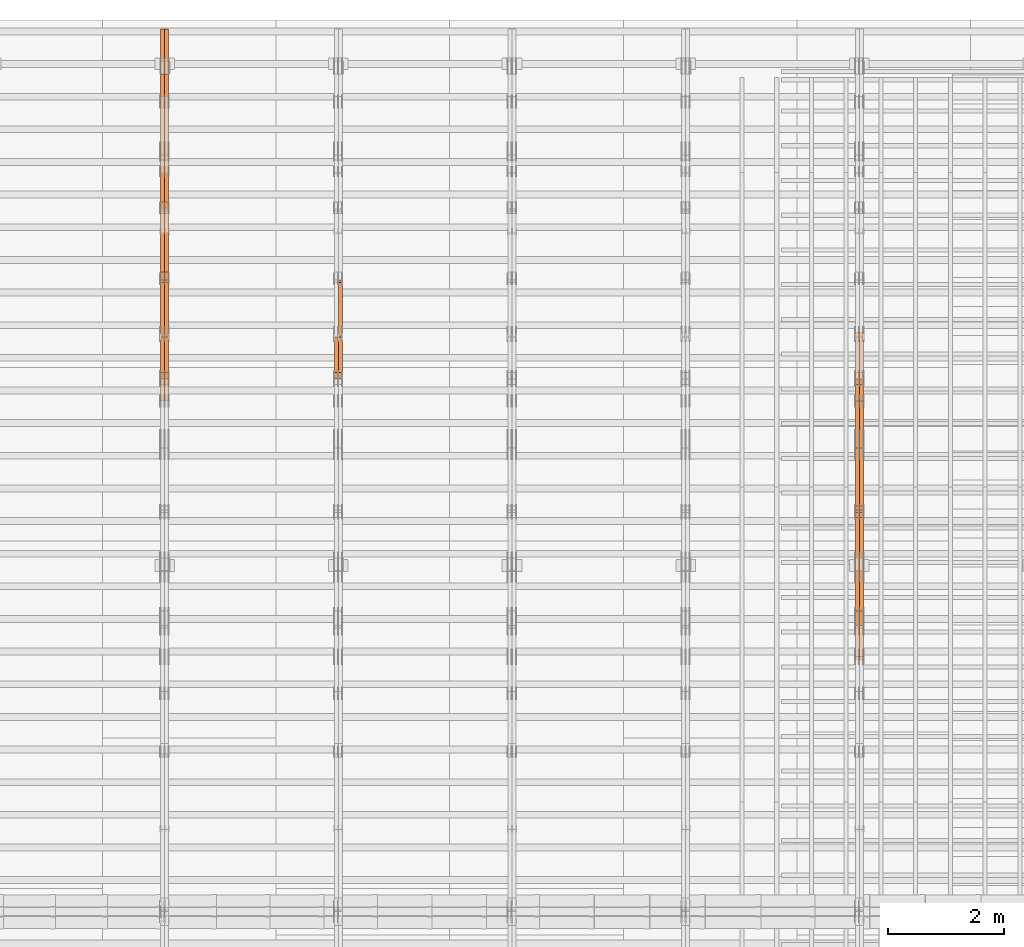
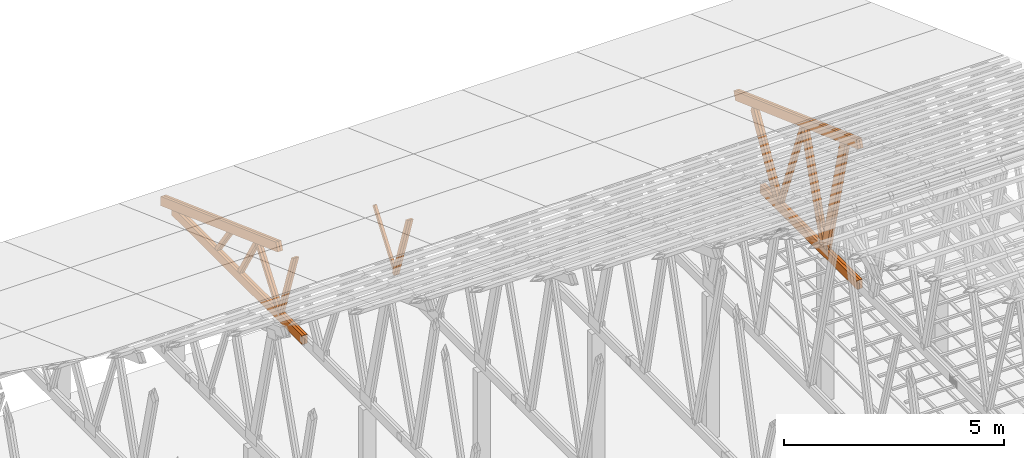
# One storey, part 61 of 189: 27 proxies.
"""IFC2X3 building model written with IfcOpenShell, lengths in millimetres."""

import ifcopenshell
import ifcopenshell.guid

model = None  # the IFC model being written
_history = None  # IfcOwnerHistory: only IFC2X3 demands one
_inside = {}  # id of a spatial element -> (the spatial element, [elements in it])
_under = {}  # id of a project, library or spatial element -> (it, [spatial elements below it])
_declared = {}  # id of a project -> (the project, [libraries it declares])
_typed = {}  # id of a type object -> (the type object, [elements of that type])
_made_of = {}  # id of a material, layer set ... -> (it, [elements and type objects made of it])


def new_model(schema):
    """Start an empty IFC model of exactly this schema.

    Asked for "IFC4X3", IfcOpenShell would pick the latest addendum, in which some entities
    have other attributes; the version numbers below select the first issue.
    IFC2X3 requires an IfcOwnerHistory on every rooted entity: one is made here for all.
    """
    global model, _history
    if schema == "IFC4X3":
        model = ifcopenshell.file(schema_version=(4, 3, 0, 0))
    else:
        model = ifcopenshell.file(schema=schema)
    _inside.clear()
    _under.clear()
    _declared.clear()
    _typed.clear()
    _made_of.clear()
    _history = None
    if model.schema == "IFC2X3":
        org = make("IfcOrganization", Name="unknown")
        user = make(
            "IfcPersonAndOrganization",
            ThePerson=make("IfcPerson", FamilyName="unknown"),
            TheOrganization=org,
        )
        app = make(
            "IfcApplication",
            ApplicationDeveloper=org,
            Version="unknown",
            ApplicationFullName="unknown",
            ApplicationIdentifier="unknown",
        )
        _history = make(
            "IfcOwnerHistory",
            OwningUser=user,
            OwningApplication=app,
            ChangeAction="ADDED",
            CreationDate=0,
        )
    return model


def make(cls, **values):
    """One entity of the class cls with the attributes given. An attribute that is None is left unset."""
    return model.create_entity(
        cls, **{name: value for name, value in values.items() if value is not None}
    )


def entity(cls, *values):
    """Any entity or typed value of the class cls, its attributes in the order of the schema. None: left unset."""
    e = model.create_entity(cls)
    for i, value in enumerate(values):
        if value is not None:
            e[i] = value
    return e


def rooted(cls, **values):
    """An entity with a GlobalId (a new one), such as an element, a storey or a relation."""
    return make(cls, GlobalId=ifcopenshell.guid.new(), OwnerHistory=_history, **values)


def si_unit(unit_type, name, prefix=None):
    """IfcSIUnit, for example si_unit("LENGTHUNIT", "METRE", prefix="MILLI")."""
    return make("IfcSIUnit", UnitType=unit_type, Prefix=prefix, Name=name)


def converted_unit(unit_type, name, factor, base, dimensions=None, offset=None):
    """IfcConversionBasedUnit, such as the inch: factor (a typed value) times the base unit."""
    return make(
        "IfcConversionBasedUnit"
        if offset is None
        else "IfcConversionBasedUnitWithOffset",
        ConversionOffset=offset,
        Dimensions=None
        if dimensions is None
        else entity("IfcDimensionalExponents", *dimensions),
        UnitType=unit_type,
        Name=name,
        ConversionFactor=make(
            "IfcMeasureWithUnit", ValueComponent=factor, UnitComponent=base
        ),
    )


def derived_unit(unit_type, elements):
    """IfcDerivedUnit: a product of units, each with its exponent."""
    return make(
        "IfcDerivedUnit",
        Elements=[
            make("IfcDerivedUnitElement", Unit=unit, Exponent=power)
            for unit, power in elements
        ],
        UnitType=unit_type,
    )


def assignment(units):
    """IfcUnitAssignment: the units of a project."""
    return None if units is None else make("IfcUnitAssignment", Units=units)


def point(xyz):
    """IfcCartesianPoint."""
    return None if xyz is None else make("IfcCartesianPoint", Coordinates=xyz)


def direction(xyz):
    """IfcDirection."""
    return None if xyz is None else make("IfcDirection", DirectionRatios=xyz)


def frame(location, z_axis=None, x_axis=None):
    """IfcAxis2Placement3D, a coordinate frame: its origin and axes. An axis left out is left unset."""
    return make(
        "IfcAxis2Placement3D",
        Location=point(location),
        Axis=direction(z_axis),
        RefDirection=direction(x_axis),
    )


def frame_2d(location, x_axis=None):
    """IfcAxis2Placement2D, a coordinate frame in the plane: its origin and x axis."""
    return make(
        "IfcAxis2Placement2D", Location=point(location), RefDirection=direction(x_axis)
    )


def origin():
    """The frame at (0, 0, 0) with its axes left unset."""
    return frame((0.0, 0.0, 0.0))


def origin_2d_with_axis():
    """The frame at (0, 0) in the plane with the x axis (1, 0) written out."""
    return frame_2d((0.0, 0.0), x_axis=(1.0, 0.0))


def place(relative_to, where):
    """IfcLocalPlacement: puts the frame where relative to a parent placement (None: the world)."""
    return make(
        "IfcLocalPlacement", PlacementRelTo=relative_to, RelativePlacement=where
    )


def context(
    kind, dimensions, precision=None, world=None, true_north=None, identifier=None
):
    """IfcGeometricRepresentationContext, for example the 3D "Model" context."""
    return make(
        "IfcGeometricRepresentationContext",
        ContextIdentifier=identifier,
        ContextType=kind,
        CoordinateSpaceDimension=dimensions,
        Precision=precision,
        WorldCoordinateSystem=world,
        TrueNorth=true_north,
    )


def subcontext(parent, identifier, kind, view, scale=None):
    """IfcGeometricRepresentationSubContext, for example "Body" below "Model"."""
    return make(
        "IfcGeometricRepresentationSubContext",
        ContextIdentifier=identifier,
        ContextType=kind,
        ParentContext=parent,
        TargetScale=scale,
        TargetView=view,
    )


def project(units=None, contexts=None):
    """IfcProject with its units and contexts."""
    return rooted(
        "IfcProject",
        Name="project",
        RepresentationContexts=contexts,
        UnitsInContext=assignment(units),
    )


def spatial(cls, under=None, at=None, **own):
    """A site, building, storey or space (cls), placed at a placement, below another one or the project."""
    s = rooted(cls, ObjectPlacement=at, **own)
    if under is not None:
        _under.setdefault(under.id(), (under, []))[1].append(s)
    return s


def polyline(points):
    """IfcPolyline through the points."""
    return make("IfcPolyline", Points=[point(p) for p in points])


def profile(cls, at=None, kind="AREA", **sizes):
    """A parametric profile (cls). Its sizes go by their IFC names, for example OverallWidth=200.0."""
    return make(cls, ProfileType=kind, Position=at, **sizes)


def rectangle(**sizes):
    """IfcRectangleProfileDef."""
    return profile("IfcRectangleProfileDef", **sizes)


def outline(outer, holes=None, kind="AREA"):
    """IfcArbitraryClosedProfileDef: a profile drawn as a closed curve; with holes, ...WithVoids."""
    if holes is None:
        return make("IfcArbitraryClosedProfileDef", ProfileType=kind, OuterCurve=outer)
    return make(
        "IfcArbitraryProfileDefWithVoids",
        ProfileType=kind,
        OuterCurve=outer,
        InnerCurves=holes,
    )


def extrude(swept, where, along, depth):
    """IfcExtrudedAreaSolid: the profile swept, set in the frame where, extruded along a direction by depth."""
    return make(
        "IfcExtrudedAreaSolid",
        SweptArea=swept,
        Position=where,
        ExtrudedDirection=direction(along),
        Depth=depth,
    )


def shape(context_of_items, identifier, shape_type, items):
    """IfcShapeRepresentation: the items that make up one representation, for example the "Body"."""
    return make(
        "IfcShapeRepresentation",
        ContextOfItems=context_of_items,
        RepresentationIdentifier=identifier,
        RepresentationType=shape_type,
        Items=items,
    )


def source(mapping_origin, context_of_items, identifier, shape_type, items):
    """IfcRepresentationMap: a shape defined once, which mapped items show again and again."""
    return make(
        "IfcRepresentationMap",
        MappingOrigin=mapping_origin,
        MappedRepresentation=shape(context_of_items, identifier, shape_type, items),
    )


def transform(
    local_origin,
    x_axis=None,
    y_axis=None,
    z_axis=None,
    scale=None,
    scale2=None,
    scale3=None,
    uniform=True,
):
    """IfcCartesianTransformationOperator3D, or its non-uniform kind. x_axis, y_axis, z_axis: its Axis1, 2, 3."""
    if uniform:
        return make(
            "IfcCartesianTransformationOperator3D",
            Axis1=direction(x_axis),
            Axis2=direction(y_axis),
            LocalOrigin=point(local_origin),
            Scale=scale,
            Axis3=direction(z_axis),
        )
    return make(
        "IfcCartesianTransformationOperator3DnonUniform",
        Axis1=direction(x_axis),
        Axis2=direction(y_axis),
        LocalOrigin=point(local_origin),
        Scale=scale,
        Axis3=direction(z_axis),
        Scale2=scale2,
        Scale3=scale3,
    )


def mapped(mapping_source, mapping_target):
    """IfcMappedItem: shows the shape of a source again, moved by a transform."""
    return make(
        "IfcMappedItem", MappingSource=mapping_source, MappingTarget=mapping_target
    )


def material(Name=None, Category=None):
    """IfcMaterial."""
    return make("IfcMaterial", Name=Name, Category=Category)


def made_of(thing, what):
    """Note that an element or type object is made of a material, layer set ...; save() writes the relation."""
    if what is not None:
        _made_of.setdefault(what.id(), (what, []))[1].append(thing)
    return thing


def type_object(cls, material=None, **own):
    """A type object (cls), such as IfcWallType, which elements share."""
    return made_of(rooted(cls, **own), material)


def type_shapes(of_type, sources):
    """Give a type object the sources (RepresentationMaps) that its elements show as mapped items."""
    of_type.RepresentationMaps = sources


def element(
    cls,
    number,
    at=None,
    inside=None,
    cuts=None,
    type_object=None,
    material=None,
    context=None,
    identifier="Body",
    shape_type=None,
    held_by="IfcProductDefinitionShape",
    body=None,
    shapes=None,
    **own,
):
    """One element of the class cls, such as IfcWall. Its Tag is "e" and its number.

    at: its placement. inside: the storey or other place that contains it. cuts: it is an
    opening in that element (IfcRelVoidsElement). A single representation is given by context,
    identifier, shape_type and body (its items); several are given by shapes. held_by: the class
    of the entity that holds the representations. save() writes the other relations.
    """
    e = rooted(cls, Tag="e%d" % number, ObjectPlacement=at, **own)
    if body is not None:
        shapes = [shape(context, identifier, shape_type, body)]
    if shapes is not None:
        e.Representation = make(held_by, Representations=shapes)
    if inside is not None:
        _inside.setdefault(inside.id(), (inside, []))[1].append(e)
    if cuts is not None:
        rooted(
            "IfcRelVoidsElement", RelatingBuildingElement=cuts, RelatedOpeningElement=e
        )
    if type_object is not None:
        _typed.setdefault(type_object.id(), (type_object, []))[1].append(e)
    return made_of(e, material)


def aggregate(whole, parts):
    """IfcRelAggregates: a whole, such as a stair, and the parts it consists of."""
    return rooted("IfcRelAggregates", RelatingObject=whole, RelatedObjects=parts)


def save(model, path):
    """Write the relations noted so far, then the file.

    IfcRelAggregates (storeys below a building ...), IfcRelContainedInSpatialStructure (elements
    in a storey), IfcRelDefinesByType, IfcRelAssociatesMaterial and IfcRelDeclares: one each for
    every whole, place, type object, material and project.
    """
    for whole, parts in _under.values():
        aggregate(whole, parts)
    for where, things in _inside.values():
        rooted(
            "IfcRelContainedInSpatialStructure",
            RelatedElements=things,
            RelatingStructure=where,
        )
    for kind, things in _typed.values():
        rooted("IfcRelDefinesByType", RelatedObjects=things, RelatingType=kind)
    for what, things in _made_of.values():
        rooted("IfcRelAssociatesMaterial", RelatedObjects=things, RelatingMaterial=what)
    for by, libraries in _declared.values():
        rooted("IfcRelDeclares", RelatingContext=by, RelatedDefinitions=libraries)
    model.write(path)


model = new_model("IFC2X3")

# Units and contexts
model_context = context("Model", 3, precision=0.01, world=origin(), true_north=direction((6.12303176911189e-17, 1.0)))
body_context = subcontext(model_context, "Body", "Model", "MODEL_VIEW")
ifc_project = project(units=[si_unit("LENGTHUNIT", "METRE", prefix="MILLI"), si_unit("AREAUNIT", "SQUARE_METRE"), si_unit("VOLUMEUNIT", "CUBIC_METRE"), converted_unit("PLANEANGLEUNIT", "DEGREE", entity("IfcRatioMeasure", 0.0174532925199433), si_unit("PLANEANGLEUNIT", "RADIAN"), dimensions=[0, 0, 0, 0, 0, 0, 0]), si_unit("MASSUNIT", "GRAM", prefix="KILO"), derived_unit("MASSDENSITYUNIT", [(si_unit("MASSUNIT", "GRAM", prefix="KILO"), 1), (si_unit("LENGTHUNIT", "METRE"), -3)]), si_unit("TIMEUNIT", "SECOND"), si_unit("FREQUENCYUNIT", "HERTZ"), si_unit("THERMODYNAMICTEMPERATUREUNIT", "DEGREE_CELSIUS"), derived_unit("THERMALTRANSMITTANCEUNIT", [(si_unit("MASSUNIT", "GRAM", prefix="KILO"), 1), (si_unit("THERMODYNAMICTEMPERATUREUNIT", "KELVIN"), -1), (si_unit("TIMEUNIT", "SECOND"), -3)]), derived_unit("VOLUMETRICFLOWRATEUNIT", [(si_unit("LENGTHUNIT", "METRE"), 3), (si_unit("TIMEUNIT", "SECOND"), -1)]), si_unit("ELECTRICCURRENTUNIT", "AMPERE"), si_unit("ELECTRICVOLTAGEUNIT", "VOLT"), si_unit("POWERUNIT", "WATT"), si_unit("FORCEUNIT", "NEWTON"), si_unit("ILLUMINANCEUNIT", "LUX"), si_unit("LUMINOUSFLUXUNIT", "LUMEN"), si_unit("LUMINOUSINTENSITYUNIT", "CANDELA"), derived_unit("USERDEFINED", [(si_unit("MASSUNIT", "GRAM", prefix="KILO"), -1), (si_unit("LENGTHUNIT", "METRE"), -2), (si_unit("TIMEUNIT", "SECOND"), 3), (si_unit("LUMINOUSFLUXUNIT", "LUMEN"), 1)]), derived_unit("LINEARVELOCITYUNIT", [(si_unit("LENGTHUNIT", "METRE"), 1), (si_unit("TIMEUNIT", "SECOND"), -1)]), si_unit("PRESSUREUNIT", "PASCAL"), derived_unit("USERDEFINED", [(si_unit("LENGTHUNIT", "METRE"), -2), (si_unit("MASSUNIT", "GRAM", prefix="KILO"), 1), (si_unit("TIMEUNIT", "SECOND"), -2)])], contexts=[model_context])

# Site, building, storey
site_placement = place(None, origin())
site = spatial("IfcSite", under=ifc_project, at=site_placement, CompositionType="ELEMENT")
building_placement = place(site_placement, origin())
building = spatial("IfcBuilding", under=site, at=building_placement, CompositionType="ELEMENT")
storey_placement = place(building_placement, origin())
storey = spatial("IfcBuildingStorey", under=building, at=storey_placement, Name="Default", CompositionType="ELEMENT", Elevation=0.0)

# Proxies
ifc_material_1 = material(Name="IfcSurfaceStyle #241136")
building_element_proxy_type_1 = type_object("IfcBuildingElementProxyType", Name="T1-W1 241134", PredefinedType="NOTDEFINED", material=ifc_material_1)
shared_shape_1 = source(origin(), body_context, "Body", "SweptSolid", [
    extrude(outline(polyline([(-1996.99427801396, -109.999889649051), (1271.09905152223, -109.999889649051), (1448.88120817726, -0.000113190727324008), (1421.70802776002, 109.999946244415), (-2144.69400944554, 109.999946244415), (-1996.99427801396, -109.999889649051)])), frame((1448.88120817726, 110.000265670598, 0.0), z_axis=(0.0, 0.0, 1.0), x_axis=(-1.0, 0.0, 0.0)), (0.0, 0.0, 1.0), 69.9999999999998),
])
type_shapes(building_element_proxy_type_1, [shared_shape_1])
proxy_1_placement = place(building_placement, frame((45300.0, 20558.6774904859, 218.61972674968), z_axis=(-1.0, 0.0, 0.0), x_axis=(0.0, -0.239819839925979, 0.970817410421691)))
element("IfcBuildingElementProxy", 1, at=proxy_1_placement, inside=storey, type_object=building_element_proxy_type_1, material=ifc_material_1, Name="T1-W1", context=body_context, shape_type="MappedRepresentation", body=[
    mapped(shared_shape_1, transform((0.0, 0.0, 0.0), scale=1.0)),
])
ifc_material_2 = material(Name="IfcSurfaceStyle #241070")
building_element_proxy_type_2 = type_object("IfcBuildingElementProxyType", Name="T1-W1 241068", PredefinedType="NOTDEFINED", material=ifc_material_2)
shared_shape_2 = source(origin(), body_context, "Body", "SweptSolid", [
    extrude(outline(polyline([(-1996.99427801396, -109.999889649051), (1271.09905152223, -109.999889649051), (1448.88120817726, -0.000113190727324008), (1421.70802776002, 109.999946244415), (-2144.69400944554, 109.999946244415), (-1996.99427801396, -109.999889649051)])), frame((1448.88120817726, 110.000265670598, 0.0), z_axis=(0.0, 0.0, 1.0), x_axis=(-1.0, 0.0, 0.0)), (0.0, 0.0, 1.0), 69.9999999999998),
])
type_shapes(building_element_proxy_type_2, [shared_shape_2])
proxy_2_placement = place(building_placement, frame((45230.0, 20558.6774904859, 218.61972674968), z_axis=(-1.0, 0.0, 0.0), x_axis=(0.0, -0.239819839925979, 0.970817410421691)))
element("IfcBuildingElementProxy", 2, at=proxy_2_placement, inside=storey, type_object=building_element_proxy_type_2, material=ifc_material_2, Name="T1-W1", context=body_context, shape_type="MappedRepresentation", body=[
    mapped(shared_shape_2, transform((0.0, 0.0, 0.0), scale=1.0)),
])
ifc_material_3 = material(Name="IfcSurfaceStyle #240872")
building_element_proxy_type_3 = type_object("IfcBuildingElementProxyType", Name="T1-W4 240870", PredefinedType="NOTDEFINED", material=ifc_material_3)
shared_shape_3 = source(origin(), body_context, "Body", "SweptSolid", [
    extrude(outline(polyline([(-1742.90513395849, -84.9997422414737), (1181.3544167489, -84.9997422414737), (1178.19398821251, -0.000208932978430543), (1071.44989130457, 84.999846707963), (-1688.09316230749, 84.999846707963), (-1742.90513395849, -84.9997422414737)])), frame((1181.35452116422, 84.999886337523, 0.0), z_axis=(0.0, 0.0, 1.0), x_axis=(-1.0, 0.0, 0.0)), (0.0, 0.0, 1.0), 69.9999999999998),
])
type_shapes(building_element_proxy_type_3, [shared_shape_3])
proxy_3_placement = place(building_placement, frame((45300.0, 21724.6281517871, 2976.00232464744), z_axis=(-1.0, 0.0, 0.0), x_axis=(0.0, -0.306868406216495, -0.951751953644514)))
element("IfcBuildingElementProxy", 3, at=proxy_3_placement, inside=storey, type_object=building_element_proxy_type_3, material=ifc_material_3, Name="T1-W4", context=body_context, shape_type="MappedRepresentation", body=[
    mapped(shared_shape_3, transform((0.0, 0.0, 0.0), scale=1.0)),
])
ifc_material_4 = material(Name="IfcSurfaceStyle #240806")
building_element_proxy_type_4 = type_object("IfcBuildingElementProxyType", Name="T1-W4 240804", PredefinedType="NOTDEFINED", material=ifc_material_4)
shared_shape_4 = source(origin(), body_context, "Body", "SweptSolid", [
    extrude(outline(polyline([(-1742.90513395849, -84.9997422414737), (1181.3544167489, -84.9997422414737), (1178.19398821251, -0.000208932978430543), (1071.44989130457, 84.999846707963), (-1688.09316230749, 84.999846707963), (-1742.90513395849, -84.9997422414737)])), frame((1181.35452116422, 84.999886337523, 0.0), z_axis=(0.0, 0.0, 1.0), x_axis=(-1.0, 0.0, 0.0)), (0.0, 0.0, 1.0), 69.9999999999998),
])
type_shapes(building_element_proxy_type_4, [shared_shape_4])
proxy_4_placement = place(building_placement, frame((45230.0, 21724.6281517871, 2976.00232464744), z_axis=(-1.0, 0.0, 0.0), x_axis=(0.0, -0.306868406216495, -0.951751953644514)))
element("IfcBuildingElementProxy", 4, at=proxy_4_placement, inside=storey, type_object=building_element_proxy_type_4, material=ifc_material_4, Name="T1-W4", context=body_context, shape_type="MappedRepresentation", body=[
    mapped(shared_shape_4, transform((0.0, 0.0, 0.0), scale=1.0)),
])
ifc_material_5 = material(Name="IfcSurfaceStyle #240608")
building_element_proxy_type_5 = type_object("IfcBuildingElementProxyType", Name="T1-W8 240606", PredefinedType="NOTDEFINED", material=ifc_material_5)
shared_shape_5 = source(origin(), body_context, "Body", "SweptSolid", [
    extrude(outline(polyline([(-1700.10906247918, -47.4998559987011), (1140.60243146647, -47.4998559987011), (1179.56122089033, 0.000120838919977206), (1161.65086478184, 47.4997955792411), (-1781.70545465947, 47.4997955792411), (-1700.10906247918, -47.4998559987011)])), frame((1179.56128464708, 47.5000634692093, 0.0), z_axis=(0.0, 0.0, 1.0), x_axis=(-1.0, 0.0, 0.0)), (0.0, 0.0, 1.0), 69.9999999999998),
])
type_shapes(building_element_proxy_type_5, [shared_shape_5])
proxy_5_placement = place(building_placement, frame((45300.0, 22687.5385403115, 228.241249073207), z_axis=(-1.0, 0.0, 0.0), x_axis=(0.0, -0.352814979177604, 0.93569310698963)))
element("IfcBuildingElementProxy", 5, at=proxy_5_placement, inside=storey, type_object=building_element_proxy_type_5, material=ifc_material_5, Name="T1-W8", context=body_context, shape_type="MappedRepresentation", body=[
    mapped(shared_shape_5, transform((0.0, 0.0, 0.0), scale=1.0)),
])
ifc_material_6 = material(Name="IfcSurfaceStyle #240542")
building_element_proxy_type_6 = type_object("IfcBuildingElementProxyType", Name="T1-W8 240540", PredefinedType="NOTDEFINED", material=ifc_material_6)
shared_shape_6 = source(origin(), body_context, "Body", "SweptSolid", [
    extrude(outline(polyline([(-1700.10906247918, -47.4998559987011), (1140.60243146647, -47.4998559987011), (1179.56122089033, 0.000120838919977206), (1161.65086478184, 47.4997955792411), (-1781.70545465947, 47.4997955792411), (-1700.10906247918, -47.4998559987011)])), frame((1179.56128464708, 47.5000634692093, 0.0), z_axis=(0.0, 0.0, 1.0), x_axis=(-1.0, 0.0, 0.0)), (0.0, 0.0, 1.0), 69.9999999999998),
])
type_shapes(building_element_proxy_type_6, [shared_shape_6])
proxy_6_placement = place(building_placement, frame((45230.0, 22687.5385403115, 228.241249073207), z_axis=(-1.0, 0.0, 0.0), x_axis=(0.0, -0.352814979177604, 0.93569310698963)))
element("IfcBuildingElementProxy", 6, at=proxy_6_placement, inside=storey, type_object=building_element_proxy_type_6, material=ifc_material_6, Name="T1-W8", context=body_context, shape_type="MappedRepresentation", body=[
    mapped(shared_shape_6, transform((0.0, 0.0, 0.0), scale=1.0)),
])
ifc_material_7 = material(Name="IfcSurfaceStyle #240344")
building_element_proxy_type_7 = type_object("IfcBuildingElementProxyType", Name="T1-W2 240342", PredefinedType="NOTDEFINED", material=ifc_material_7)
shared_shape_7 = source(origin(), body_context, "Body", "SweptSolid", [
    extrude(outline(polyline([(-1361.89144606429, -97.5000598486876), (887.613245225805, -97.5000598486876), (904.774262962339, 0.000302345139042259), (818.892339969004, 97.4999086761182), (-1249.38840209286, 97.4999086761182), (-1361.89144606429, -97.5000598486876)])), frame((904.774262962339, 97.5000966763391, 0.0), z_axis=(0.0, 0.0, 1.0), x_axis=(-1.0, 0.0, 0.0)), (0.0, 0.0, 1.0), 69.9999999999999),
])
type_shapes(building_element_proxy_type_7, [shared_shape_7])
proxy_7_placement = place(building_placement, frame((45300.0, 24033.6159173732, 2110.89189244614), z_axis=(-1.0, 0.0, 0.0), x_axis=(0.0, -0.5, -0.866025403784439)))
element("IfcBuildingElementProxy", 7, at=proxy_7_placement, inside=storey, type_object=building_element_proxy_type_7, material=ifc_material_7, Name="T1-W2", context=body_context, shape_type="MappedRepresentation", body=[
    mapped(shared_shape_7, transform((0.0, 0.0, 0.0), scale=1.0)),
])
ifc_material_8 = material(Name="IfcSurfaceStyle #240278")
building_element_proxy_type_8 = type_object("IfcBuildingElementProxyType", Name="T1-W2 240276", PredefinedType="NOTDEFINED", material=ifc_material_8)
shared_shape_8 = source(origin(), body_context, "Body", "SweptSolid", [
    extrude(outline(polyline([(-1361.89144606429, -97.5000598486876), (887.613245225805, -97.5000598486876), (904.774262962339, 0.000302345139042259), (818.892339969004, 97.4999086761182), (-1249.38840209286, 97.4999086761182), (-1361.89144606429, -97.5000598486876)])), frame((904.774262962339, 97.5000966763391, 0.0), z_axis=(0.0, 0.0, 1.0), x_axis=(-1.0, 0.0, 0.0)), (0.0, 0.0, 1.0), 69.9999999999999),
])
type_shapes(building_element_proxy_type_8, [shared_shape_8])
proxy_8_placement = place(building_placement, frame((45230.0, 24033.6159173732, 2110.89189244614), z_axis=(-1.0, 0.0, 0.0), x_axis=(0.0, -0.5, -0.866025403784439)))
element("IfcBuildingElementProxy", 8, at=proxy_8_placement, inside=storey, type_object=building_element_proxy_type_8, material=ifc_material_8, Name="T1-W2", context=body_context, shape_type="MappedRepresentation", body=[
    mapped(shared_shape_8, transform((0.0, 0.0, 0.0), scale=1.0)),
])
ifc_material_9 = material(Name="IfcSurfaceStyle #238268")
building_element_proxy_type_9 = type_object("IfcBuildingElementProxyType", Name="T1-B4 238266", PredefinedType="NOTDEFINED", material=ifc_material_9)
shared_shape_9 = source(origin(), body_context, "Body", "SweptSolid", [
    extrude(rectangle(XDim=4408.2412109375, YDim=245.000000000001, at=origin_2d_with_axis()), frame((2204.12060546875, 122.5, 0.0), z_axis=(0.0, 0.0, 1.0), x_axis=(-1.0, 0.0, 0.0)), (0.0, 0.0, 1.0), 69.9999999999997),
])
type_shapes(building_element_proxy_type_9, [shared_shape_9])
proxy_9_placement = place(building_placement, frame((45300.0, 19161.7587890625, 245.0), z_axis=(-1.0, 0.0, 0.0), x_axis=(0.0, 1.0, 0.0)))
element("IfcBuildingElementProxy", 9, at=proxy_9_placement, inside=storey, type_object=building_element_proxy_type_9, material=ifc_material_9, Name="T1-B4", context=body_context, shape_type="MappedRepresentation", body=[
    mapped(shared_shape_9, transform((0.0, 0.0, 0.0), scale=1.0)),
])
ifc_material_10 = material(Name="IfcSurfaceStyle #238211")
building_element_proxy_type_10 = type_object("IfcBuildingElementProxyType", Name="T1-B4 238209", PredefinedType="NOTDEFINED", material=ifc_material_10)
shared_shape_10 = source(origin(), body_context, "Body", "SweptSolid", [
    extrude(rectangle(XDim=4408.2412109375, YDim=245.000000000001, at=origin_2d_with_axis()), frame((2204.12060546875, 122.5, 0.0), z_axis=(0.0, 0.0, 1.0), x_axis=(-1.0, 0.0, 0.0)), (0.0, 0.0, 1.0), 69.9999999999997),
])
type_shapes(building_element_proxy_type_10, [shared_shape_10])
proxy_10_placement = place(building_placement, frame((45230.0, 19161.7587890625, 245.0), z_axis=(-1.0, 0.0, 0.0), x_axis=(0.0, 1.0, 0.0)))
element("IfcBuildingElementProxy", 10, at=proxy_10_placement, inside=storey, type_object=building_element_proxy_type_10, material=ifc_material_10, Name="T1-B4", context=body_context, shape_type="MappedRepresentation", body=[
    mapped(shared_shape_10, transform((0.0, 0.0, 0.0), scale=1.0)),
])
ifc_material_11 = material(Name="IfcSurfaceStyle #237224")
building_element_proxy_type_11 = type_object("IfcBuildingElementProxyType", Name="T1-T1 237222", PredefinedType="NOTDEFINED", material=ifc_material_11)
shared_shape_11 = source(origin(), body_context, "Body", "SweptSolid", [
    extrude(outline(polyline([(-2964.99982426074, -122.499947708046), (2964.99981923522, -122.499947708046), (2964.99984513599, 122.499947708046), (-2964.99984011047, 122.499947708046), (-2964.99982426074, -122.499947708046)])), frame((2964.99984513599, 122.499998966405, 0.0), z_axis=(0.0, 0.0, 1.0), x_axis=(-1.0, 0.0, 0.0)), (0.0, 0.0, 1.0), 69.9999999999996),
])
type_shapes(building_element_proxy_type_11, [shared_shape_11])
proxy_11_placement = place(building_placement, frame((45300.0, 24681.3398262186, 1893.12531804384), z_axis=(-1.0, 0.0, 0.0), x_axis=(0.0, -0.939692620785908, 0.342020143325669)))
element("IfcBuildingElementProxy", 11, at=proxy_11_placement, inside=storey, type_object=building_element_proxy_type_11, material=ifc_material_11, Name="T1-T1", context=body_context, shape_type="MappedRepresentation", body=[
    mapped(shared_shape_11, transform((0.0, 0.0, 0.0), scale=1.0)),
])
ifc_material_12 = material(Name="IfcSurfaceStyle #237167")
building_element_proxy_type_12 = type_object("IfcBuildingElementProxyType", Name="T1-T1 237165", PredefinedType="NOTDEFINED", material=ifc_material_12)
shared_shape_12 = source(origin(), body_context, "Body", "SweptSolid", [
    extrude(outline(polyline([(-2964.99982426074, -122.499947708046), (2964.99981923522, -122.499947708046), (2964.99984513599, 122.499947708046), (-2964.99984011047, 122.499947708046), (-2964.99982426074, -122.499947708046)])), frame((2964.99984513599, 122.499998966405, 0.0), z_axis=(0.0, 0.0, 1.0), x_axis=(-1.0, 0.0, 0.0)), (0.0, 0.0, 1.0), 69.9999999999996),
])
type_shapes(building_element_proxy_type_12, [shared_shape_12])
proxy_12_placement = place(building_placement, frame((45230.0, 24681.3398262186, 1893.12531804384), z_axis=(-1.0, 0.0, 0.0), x_axis=(0.0, -0.939692620785908, 0.342020143325669)))
element("IfcBuildingElementProxy", 12, at=proxy_12_placement, inside=storey, type_object=building_element_proxy_type_12, material=ifc_material_12, Name="T1-T1", context=body_context, shape_type="MappedRepresentation", body=[
    mapped(shared_shape_12, transform((0.0, 0.0, 0.0), scale=1.0)),
])
ifc_material_13 = material(Name="IfcSurfaceStyle #192710")
building_element_proxy_type_13 = type_object("IfcBuildingElementProxyType", Name="T1-W9 192708", PredefinedType="NOTDEFINED", material=ifc_material_13)
shared_shape_13 = source(origin(), body_context, "Body", "SweptSolid", [
    extrude(outline(polyline([(-1151.44310138162, -47.5000079487596), (776.329826327547, -47.5000079487596), (809.267611644053, -8.1966354137375e-07), (793.242530238244, 47.5000083585914), (-1227.39686682822, 47.5000083585914), (-1151.44310138162, -47.5000079487596)])), frame((809.267685789073, 47.5000083585914, 0.0), z_axis=(0.0, 0.0, 1.0), x_axis=(-1.0, 0.0, 0.0)), (0.0, 0.0, 1.0), 69.9999999999999),
])
type_shapes(building_element_proxy_type_13, [shared_shape_13])
proxy_13_placement = place(building_placement, frame((36300.0, 24600.2198992919, 229.815691184017), z_axis=(-1.0, 0.0, 0.0), x_axis=(0.0, -0.31966811847134, 0.947529574226047)))
element("IfcBuildingElementProxy", 13, at=proxy_13_placement, inside=storey, type_object=building_element_proxy_type_13, material=ifc_material_13, Name="T1-W9", context=body_context, shape_type="MappedRepresentation", body=[
    mapped(shared_shape_13, transform((0.0, 0.0, 0.0), scale=1.0)),
])
ifc_material_14 = material(Name="IfcSurfaceStyle #192644")
building_element_proxy_type_14 = type_object("IfcBuildingElementProxyType", Name="T1-W9 192642", PredefinedType="NOTDEFINED", material=ifc_material_14)
shared_shape_14 = source(origin(), body_context, "Body", "SweptSolid", [
    extrude(outline(polyline([(-1151.44310138162, -47.5000079487596), (776.329826327547, -47.5000079487596), (809.267611644053, -8.1966354137375e-07), (793.242530238244, 47.5000083585914), (-1227.39686682822, 47.5000083585914), (-1151.44310138162, -47.5000079487596)])), frame((809.267685789073, 47.5000083585914, 0.0), z_axis=(0.0, 0.0, 1.0), x_axis=(-1.0, 0.0, 0.0)), (0.0, 0.0, 1.0), 69.9999999999999),
])
type_shapes(building_element_proxy_type_14, [shared_shape_14])
proxy_14_placement = place(building_placement, frame((36230.0, 24600.2198992919, 229.815691184017), z_axis=(-1.0, 0.0, 0.0), x_axis=(0.0, -0.31966811847134, 0.947529574226047)))
element("IfcBuildingElementProxy", 14, at=proxy_14_placement, inside=storey, type_object=building_element_proxy_type_14, material=ifc_material_14, Name="T1-W9", context=body_context, shape_type="MappedRepresentation", body=[
    mapped(shared_shape_14, transform((0.0, 0.0, 0.0), scale=1.0)),
])
ifc_material_15 = material(Name="IfcSurfaceStyle #192446")
building_element_proxy_type_15 = type_object("IfcBuildingElementProxyType", Name="T1-W10 192444", PredefinedType="NOTDEFINED", material=ifc_material_15)
shared_shape_15 = source(origin(), body_context, "Body", "SweptSolid", [
    extrude(outline(polyline([(-993.240970354386, -47.5000757607337), (635.890952815036, -47.5000757607337), (650.068145237537, -1.47580554758164e-05), (629.921374092803, 47.5000831397614), (-922.639501790989, 47.5000831397614), (-993.240970354386, -47.5000757607337)])), frame((650.068173419645, 47.5002811208496, 0.0), z_axis=(0.0, 0.0, 1.0), x_axis=(-1.0, 0.0, 0.0)), (0.0, 0.0, 1.0), 69.9999999999999),
])
type_shapes(building_element_proxy_type_15, [shared_shape_15])
proxy_15_placement = place(building_placement, frame((36300.0, 25701.688098798, 1507.2920009025), z_axis=(-1.0, 0.0, 0.0), x_axis=(0.0, -0.596486092002004, -0.802623412347395)))
element("IfcBuildingElementProxy", 15, at=proxy_15_placement, inside=storey, type_object=building_element_proxy_type_15, material=ifc_material_15, Name="T1-W10", context=body_context, shape_type="MappedRepresentation", body=[
    mapped(shared_shape_15, transform((0.0, 0.0, 0.0), scale=1.0)),
])
ifc_material_16 = material(Name="IfcSurfaceStyle #176920")
building_element_proxy_type_16 = type_object("IfcBuildingElementProxyType", Name="T1-W9 176918", PredefinedType="NOTDEFINED", material=ifc_material_16)
shared_shape_16 = source(origin(), body_context, "Body", "SweptSolid", [
    extrude(outline(polyline([(-1151.44310138162, -47.5000079487596), (776.329826327547, -47.5000079487596), (809.267611644053, -8.1966354137375e-07), (793.242530238244, 47.5000083585914), (-1227.39686682822, 47.5000083585914), (-1151.44310138162, -47.5000079487596)])), frame((809.267685789073, 47.5000083585914, 0.0), z_axis=(0.0, 0.0, 1.0), x_axis=(-1.0, 0.0, 0.0)), (0.0, 0.0, 1.0), 69.9999999999999),
])
type_shapes(building_element_proxy_type_16, [shared_shape_16])
proxy_16_placement = place(building_placement, frame((33300.0, 24600.2198992919, 229.815691184017), z_axis=(-1.0, 0.0, 0.0), x_axis=(0.0, -0.31966811847134, 0.947529574226047)))
element("IfcBuildingElementProxy", 16, at=proxy_16_placement, inside=storey, type_object=building_element_proxy_type_16, material=ifc_material_16, Name="T1-W9", context=body_context, shape_type="MappedRepresentation", body=[
    mapped(shared_shape_16, transform((0.0, 0.0, 0.0), scale=1.0)),
])
ifc_material_17 = material(Name="IfcSurfaceStyle #176854")
building_element_proxy_type_17 = type_object("IfcBuildingElementProxyType", Name="T1-W9 176852", PredefinedType="NOTDEFINED", material=ifc_material_17)
shared_shape_17 = source(origin(), body_context, "Body", "SweptSolid", [
    extrude(outline(polyline([(-1151.44310138162, -47.5000079487596), (776.329826327547, -47.5000079487596), (809.267611644053, -8.1966354137375e-07), (793.242530238244, 47.5000083585914), (-1227.39686682822, 47.5000083585914), (-1151.44310138162, -47.5000079487596)])), frame((809.267685789073, 47.5000083585914, 0.0), z_axis=(0.0, 0.0, 1.0), x_axis=(-1.0, 0.0, 0.0)), (0.0, 0.0, 1.0), 69.9999999999999),
])
type_shapes(building_element_proxy_type_17, [shared_shape_17])
proxy_17_placement = place(building_placement, frame((33230.0, 24600.2198992919, 229.815691184017), z_axis=(-1.0, 0.0, 0.0), x_axis=(0.0, -0.31966811847134, 0.947529574226047)))
element("IfcBuildingElementProxy", 17, at=proxy_17_placement, inside=storey, type_object=building_element_proxy_type_17, material=ifc_material_17, Name="T1-W9", context=body_context, shape_type="MappedRepresentation", body=[
    mapped(shared_shape_17, transform((0.0, 0.0, 0.0), scale=1.0)),
])
ifc_material_18 = material(Name="IfcSurfaceStyle #176656")
building_element_proxy_type_18 = type_object("IfcBuildingElementProxyType", Name="T1-W10 176654", PredefinedType="NOTDEFINED", material=ifc_material_18)
shared_shape_18 = source(origin(), body_context, "Body", "SweptSolid", [
    extrude(outline(polyline([(-993.240970354386, -47.5000757607337), (635.890952815036, -47.5000757607337), (650.068145237537, -1.47580554758164e-05), (629.921374092803, 47.5000831397614), (-922.639501790989, 47.5000831397614), (-993.240970354386, -47.5000757607337)])), frame((650.068173419645, 47.5002811208496, 0.0), z_axis=(0.0, 0.0, 1.0), x_axis=(-1.0, 0.0, 0.0)), (0.0, 0.0, 1.0), 69.9999999999999),
])
type_shapes(building_element_proxy_type_18, [shared_shape_18])
proxy_18_placement = place(building_placement, frame((33300.0, 25701.688098798, 1507.2920009025), z_axis=(-1.0, 0.0, 0.0), x_axis=(0.0, -0.596486092002004, -0.802623412347395)))
element("IfcBuildingElementProxy", 18, at=proxy_18_placement, inside=storey, type_object=building_element_proxy_type_18, material=ifc_material_18, Name="T1-W10", context=body_context, shape_type="MappedRepresentation", body=[
    mapped(shared_shape_18, transform((0.0, 0.0, 0.0), scale=1.0)),
])
ifc_material_19 = material(Name="IfcSurfaceStyle #176590")
building_element_proxy_type_19 = type_object("IfcBuildingElementProxyType", Name="T1-W10 176588", PredefinedType="NOTDEFINED", material=ifc_material_19)
shared_shape_19 = source(origin(), body_context, "Body", "SweptSolid", [
    extrude(outline(polyline([(-993.240970354386, -47.5000757607337), (635.890952815036, -47.5000757607337), (650.068145237537, -1.47580554758164e-05), (629.921374092803, 47.5000831397614), (-922.639501790989, 47.5000831397614), (-993.240970354386, -47.5000757607337)])), frame((650.068173419645, 47.5002811208496, 0.0), z_axis=(0.0, 0.0, 1.0), x_axis=(-1.0, 0.0, 0.0)), (0.0, 0.0, 1.0), 69.9999999999999),
])
type_shapes(building_element_proxy_type_19, [shared_shape_19])
proxy_19_placement = place(building_placement, frame((33230.0, 25701.688098798, 1507.2920009025), z_axis=(-1.0, 0.0, 0.0), x_axis=(0.0, -0.596486092002004, -0.802623412347395)))
element("IfcBuildingElementProxy", 19, at=proxy_19_placement, inside=storey, type_object=building_element_proxy_type_19, material=ifc_material_19, Name="T1-W10", context=body_context, shape_type="MappedRepresentation", body=[
    mapped(shared_shape_19, transform((0.0, 0.0, 0.0), scale=1.0)),
])
ifc_material_20 = material(Name="IfcSurfaceStyle #176392")
building_element_proxy_type_20 = type_object("IfcBuildingElementProxyType", Name="T1-W11 176390", PredefinedType="NOTDEFINED", material=ifc_material_20)
shared_shape_20 = source(origin(), body_context, "Body", "SweptSolid", [
    extrude(outline(polyline([(-809.410890003667, -47.5000077306544), (561.624013869753, -47.5000077306544), (599.944137054867, -7.52294285037536e-05), (572.078784657538, 47.5000453453687), (-924.236045578491, 47.5000453453687), (-809.410890003667, -47.5000077306544)])), frame((599.944137054867, 47.5000453453687, 0.0), z_axis=(0.0, 0.0, 1.0), x_axis=(-1.0, 0.0, 0.0)), (0.0, 0.0, 1.0), 69.9999999999999),
])
type_shapes(building_element_proxy_type_20, [shared_shape_20])
proxy_20_placement = place(building_placement, frame((33300.0, 26434.7921369083, 220.965133687368), z_axis=(-1.0, 0.0, 0.0), x_axis=(0.0, -0.505995901100603, 0.862535882192381)))
element("IfcBuildingElementProxy", 20, at=proxy_20_placement, inside=storey, type_object=building_element_proxy_type_20, material=ifc_material_20, Name="T1-W11", context=body_context, shape_type="MappedRepresentation", body=[
    mapped(shared_shape_20, transform((0.0, 0.0, 0.0), scale=1.0)),
])
ifc_material_21 = material(Name="IfcSurfaceStyle #176326")
building_element_proxy_type_21 = type_object("IfcBuildingElementProxyType", Name="T1-W11 176324", PredefinedType="NOTDEFINED", material=ifc_material_21)
shared_shape_21 = source(origin(), body_context, "Body", "SweptSolid", [
    extrude(outline(polyline([(-809.410890003667, -47.5000077306544), (561.624013869753, -47.5000077306544), (599.944137054867, -7.52294285037536e-05), (572.078784657538, 47.5000453453687), (-924.236045578491, 47.5000453453687), (-809.410890003667, -47.5000077306544)])), frame((599.944137054867, 47.5000453453687, 0.0), z_axis=(0.0, 0.0, 1.0), x_axis=(-1.0, 0.0, 0.0)), (0.0, 0.0, 1.0), 69.9999999999999),
])
type_shapes(building_element_proxy_type_21, [shared_shape_21])
proxy_21_placement = place(building_placement, frame((33230.0, 26434.7921369083, 220.965133687368), z_axis=(-1.0, 0.0, 0.0), x_axis=(0.0, -0.505995901100603, 0.862535882192381)))
element("IfcBuildingElementProxy", 21, at=proxy_21_placement, inside=storey, type_object=building_element_proxy_type_21, material=ifc_material_21, Name="T1-W11", context=body_context, shape_type="MappedRepresentation", body=[
    mapped(shared_shape_21, transform((0.0, 0.0, 0.0), scale=1.0)),
])
ifc_material_22 = material(Name="IfcSurfaceStyle #175864")
building_element_proxy_type_22 = type_object("IfcBuildingElementProxyType", Name="T1-W13 175862", PredefinedType="NOTDEFINED", material=ifc_material_22)
shared_shape_22 = source(origin(), body_context, "Body", "SweptSolid", [
    extrude(outline(polyline([(-527.416466728212, -47.5000272833949), (387.658053197984, -47.5000272833949), (418.029495084182, -7.96824534414764e-06), (384.779443025059, 47.5000312675175), (-663.050524579013, 47.5000312675176), (-527.416466728212, -47.5000272833949)])), frame((418.029495084182, 47.5000671658844, 0.0), z_axis=(0.0, 0.0, 1.0), x_axis=(-1.0, 0.0, 0.0)), (0.0, 0.0, 1.0), 69.9999999999999),
])
type_shapes(building_element_proxy_type_22, [shared_shape_22])
proxy_22_placement = place(building_placement, frame((33300.0, 27471.0085508293, 217.760482033818), z_axis=(-1.0, 0.0, 0.0), x_axis=(0.0, -0.573462629043498, 0.819231721242848)))
element("IfcBuildingElementProxy", 22, at=proxy_22_placement, inside=storey, type_object=building_element_proxy_type_22, material=ifc_material_22, Name="T1-W13", context=body_context, shape_type="MappedRepresentation", body=[
    mapped(shared_shape_22, transform((0.0, 0.0, 0.0), scale=1.0)),
])
ifc_material_23 = material(Name="IfcSurfaceStyle #175798")
building_element_proxy_type_23 = type_object("IfcBuildingElementProxyType", Name="T1-W13 175796", PredefinedType="NOTDEFINED", material=ifc_material_23)
shared_shape_23 = source(origin(), body_context, "Body", "SweptSolid", [
    extrude(outline(polyline([(-527.416466728212, -47.5000272833949), (387.658053197984, -47.5000272833949), (418.029495084182, -7.96824534414764e-06), (384.779443025059, 47.5000312675175), (-663.050524579013, 47.5000312675176), (-527.416466728212, -47.5000272833949)])), frame((418.029495084182, 47.5000671658844, 0.0), z_axis=(0.0, 0.0, 1.0), x_axis=(-1.0, 0.0, 0.0)), (0.0, 0.0, 1.0), 69.9999999999999),
])
type_shapes(building_element_proxy_type_23, [shared_shape_23])
proxy_23_placement = place(building_placement, frame((33230.0, 27471.0085508293, 217.760482033818), z_axis=(-1.0, 0.0, 0.0), x_axis=(0.0, -0.573462629043498, 0.819231721242848)))
element("IfcBuildingElementProxy", 23, at=proxy_23_placement, inside=storey, type_object=building_element_proxy_type_23, material=ifc_material_23, Name="T1-W13", context=body_context, shape_type="MappedRepresentation", body=[
    mapped(shared_shape_23, transform((0.0, 0.0, 0.0), scale=1.0)),
])
ifc_material_24 = material(Name="IfcSurfaceStyle #175240")
building_element_proxy_type_24 = type_object("IfcBuildingElementProxyType", Name="T1-B1 175238", PredefinedType="NOTDEFINED", material=ifc_material_24)
shared_shape_24 = source(origin(), body_context, "Body", "SweptSolid", [
    extrude(outline(polyline([(-2430.09461669922, -125.855288696288), (3499.90538330078, -125.855288696288), (3499.90538330078, 119.144711303711), (-2139.62153320312, 119.144711303711), (-2430.09461669922, 13.4211547851552), (-2430.09461669922, -125.855288696288)])), frame((3499.90538330078, 119.144711303711, 0.0), z_axis=(0.0, 0.0, 1.0), x_axis=(-1.0, 0.0, 0.0)), (0.0, 0.0, 1.0), 69.9999999999996),
])
type_shapes(building_element_proxy_type_24, [shared_shape_24])
proxy_24_placement = place(building_placement, frame((33300.0, 23570.0, 245.0), z_axis=(-1.0, 0.0, 0.0), x_axis=(0.0, 1.0, 0.0)))
element("IfcBuildingElementProxy", 24, at=proxy_24_placement, inside=storey, type_object=building_element_proxy_type_24, material=ifc_material_24, Name="T1-B1", context=body_context, shape_type="MappedRepresentation", body=[
    mapped(shared_shape_24, transform((0.0, 0.0, 0.0), scale=1.0)),
])
ifc_material_25 = material(Name="IfcSurfaceStyle #175174")
building_element_proxy_type_25 = type_object("IfcBuildingElementProxyType", Name="T1-B1 175172", PredefinedType="NOTDEFINED", material=ifc_material_25)
shared_shape_25 = source(origin(), body_context, "Body", "SweptSolid", [
    extrude(outline(polyline([(-2430.09461669922, -125.855288696288), (3499.90538330078, -125.855288696288), (3499.90538330078, 119.144711303711), (-2139.62153320312, 119.144711303711), (-2430.09461669922, 13.4211547851552), (-2430.09461669922, -125.855288696288)])), frame((3499.90538330078, 119.144711303711, 0.0), z_axis=(0.0, 0.0, 1.0), x_axis=(-1.0, 0.0, 0.0)), (0.0, 0.0, 1.0), 69.9999999999996),
])
type_shapes(building_element_proxy_type_25, [shared_shape_25])
proxy_25_placement = place(building_placement, frame((33230.0, 23570.0, 245.0), z_axis=(-1.0, 0.0, 0.0), x_axis=(0.0, 1.0, 0.0)))
element("IfcBuildingElementProxy", 25, at=proxy_25_placement, inside=storey, type_object=building_element_proxy_type_25, material=ifc_material_25, Name="T1-B1", context=body_context, shape_type="MappedRepresentation", body=[
    mapped(shared_shape_25, transform((0.0, 0.0, 0.0), scale=1.0)),
])
ifc_material_26 = material(Name="IfcSurfaceStyle #173950")
building_element_proxy_type_26 = type_object("IfcBuildingElementProxyType", Name="T1-T2 173948", PredefinedType="NOTDEFINED", material=ifc_material_26)
shared_shape_26 = source(origin(), body_context, "Body", "SweptSolid", [
    extrude(outline(polyline([(-2807.70681121203, -122.500041939424), (2763.12044548192, -122.500041939424), (2852.29315104137, 122.500041939424), (-2807.70678531126, 122.500041939424), (-2807.70681121203, -122.500041939424)])), frame((2852.29315104137, 122.500041939424, 0.0), z_axis=(0.0, 0.0, 1.0), x_axis=(-1.0, 0.0, 0.0)), (0.0, 0.0, 1.0), 69.9999999999997),
])
type_shapes(building_element_proxy_type_26, [shared_shape_26])
proxy_26_placement = place(building_placement, frame((33300.0, 30000.0, -42.7086715698242), z_axis=(-1.0, 0.0, 0.0), x_axis=(0.0, -0.939692620785908, 0.342020143325669)))
element("IfcBuildingElementProxy", 26, at=proxy_26_placement, inside=storey, type_object=building_element_proxy_type_26, material=ifc_material_26, Name="T1-T2", context=body_context, shape_type="MappedRepresentation", body=[
    mapped(shared_shape_26, transform((0.0, 0.0, 0.0), scale=1.0)),
])
ifc_material_27 = material(Name="IfcSurfaceStyle #173893")
building_element_proxy_type_27 = type_object("IfcBuildingElementProxyType", Name="T1-T2 173891", PredefinedType="NOTDEFINED", material=ifc_material_27)
shared_shape_27 = source(origin(), body_context, "Body", "SweptSolid", [
    extrude(outline(polyline([(-2807.70681121203, -122.500041939424), (2763.12044548192, -122.500041939424), (2852.29315104137, 122.500041939424), (-2807.70678531126, 122.500041939424), (-2807.70681121203, -122.500041939424)])), frame((2852.29315104137, 122.500041939424, 0.0), z_axis=(0.0, 0.0, 1.0), x_axis=(-1.0, 0.0, 0.0)), (0.0, 0.0, 1.0), 69.9999999999997),
])
type_shapes(building_element_proxy_type_27, [shared_shape_27])
proxy_27_placement = place(building_placement, frame((33230.0, 30000.0, -42.7086715698242), z_axis=(-1.0, 0.0, 0.0), x_axis=(0.0, -0.939692620785908, 0.342020143325669)))
element("IfcBuildingElementProxy", 27, at=proxy_27_placement, inside=storey, type_object=building_element_proxy_type_27, material=ifc_material_27, Name="T1-T2", context=body_context, shape_type="MappedRepresentation", body=[
    mapped(shared_shape_27, transform((0.0, 0.0, 0.0), scale=1.0)),
])

save(model, "model.ifc")
